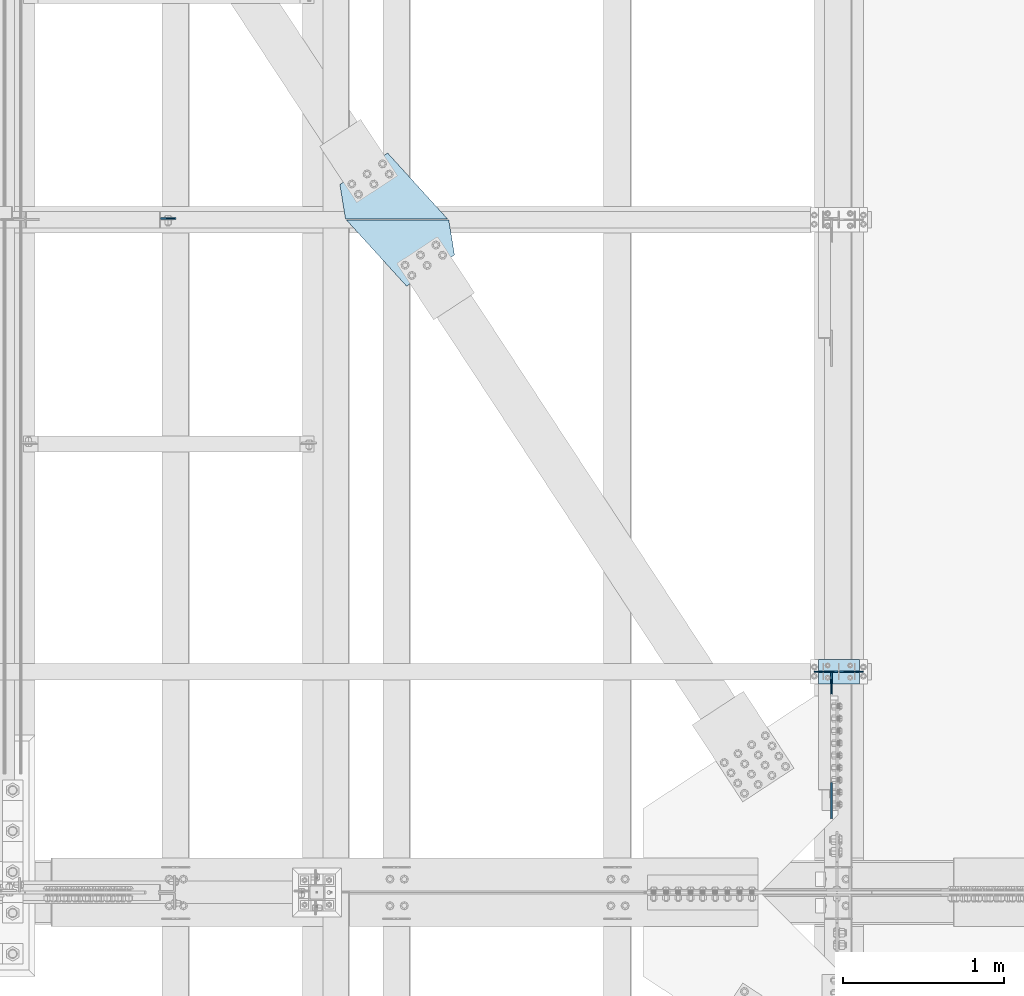
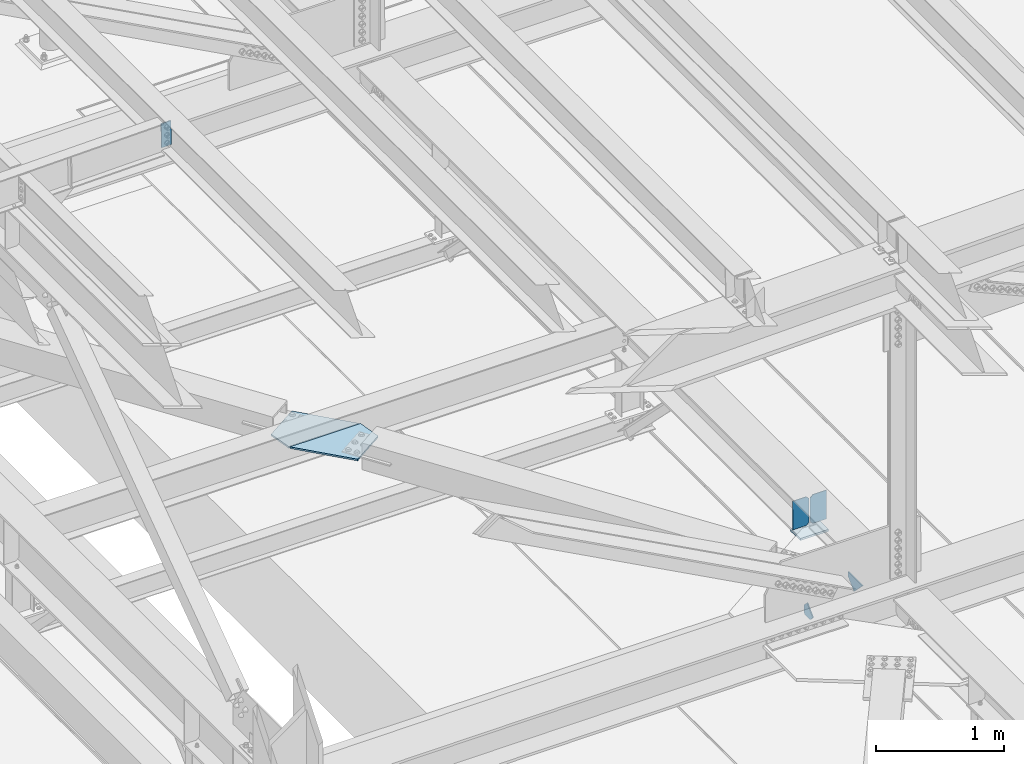
# One storey, part 3356 of 3843: 8 plates, 5 elements without a shape of their own.
"""IFC2X3 building model written with IfcOpenShell, lengths in millimetres."""

from ifc_helpers import new_model, si_unit, frame, origin_with_axes, place, context, subcontext, project, spatial, faceted_brep, material, type_object, element, aggregate, save


model = new_model("IFC2X3")

# Units and contexts
model_context = context("Model", 3, precision=1e-05, world=origin_with_axes())
body_context = subcontext(model_context, "Body", "Model", "MODEL_VIEW")
ifc_project = project(units=[si_unit("LENGTHUNIT", "METRE", prefix="MILLI"), si_unit("AREAUNIT", "SQUARE_METRE"), si_unit("VOLUMEUNIT", "CUBIC_METRE"), si_unit("MASSUNIT", "GRAM", prefix="KILO"), si_unit("TIMEUNIT", "SECOND"), si_unit("PLANEANGLEUNIT", "RADIAN"), si_unit("SOLIDANGLEUNIT", "STERADIAN"), si_unit("THERMODYNAMICTEMPERATUREUNIT", "DEGREE_CELSIUS"), si_unit("LUMINOUSINTENSITYUNIT", "LUMEN")], contexts=[model_context])

# Site, building, storey
site_placement = place(None, origin_with_axes())
site = spatial("IfcSite", under=ifc_project, at=site_placement, CompositionType="ELEMENT")
building_placement = place(site_placement, origin_with_axes())
building = spatial("IfcBuilding", under=site, at=building_placement, Name="Undefined", CompositionType="ELEMENT")
storey_placement = place(building_placement, origin_with_axes())
storey = spatial("IfcBuildingStorey", under=building, at=storey_placement, Name="Undefined", CompositionType="ELEMENT", Elevation=0.0)

# Assembly, plate
assembly_1_placement = place(storey_placement, origin_with_axes())
assembly_1 = element("IfcElementAssembly", 1, at=assembly_1_placement, inside=storey, Name="BEAM", AssemblyPlace="NOTDEFINED", PredefinedType="RIGID_FRAME")
ifc_material = material(Name="STEEL/A572-50")
plate_type_1 = type_object("IfcPlateType", PredefinedType="NOTDEFINED")
plate_1_placement = place(assembly_1_placement, frame((37938.8107286313, 71458.1407733637, 45720.3188601952), z_axis=(-0.999776269342228, -3.16699999781408e-06, -0.0211520980072162), x_axis=(0.0211520550054438, 0.0, -0.999776270257025)))
plate_1 = element("IfcPlate", 2, at=plate_1_placement, type_object=plate_type_1, material=ifc_material, Name="PLATE", context=body_context, shape_type="Brep", body=[
    faceted_brep([(0.0, -4.76249999999709, 0.0), (0.0, -4.76249999999709, 88.9000015258789), (0.0, 4.76249999999709, 88.9000015258789), (0.0, 4.76249999999709, 0.0), (228.600006102781, -4.7625000004191, 88.9000015257589), (228.600006102781, 4.76249999954598, 88.9000015257443), (228.600006103079, -4.7625000004482, 7.27595761418343e-12), (228.600006103079, 4.76249999954598, -7.27595761418343e-12)], [[[0, 1, 2, 3]], [[1, 4, 5, 2]], [[4, 6, 7, 5]], [[6, 0, 3, 7]], [[5, 7, 3, 2]], [[6, 4, 1, 0]]]),
])
aggregate(assembly_1, [plate_1])

# Assembly, plates
assembly_2_placement = place(storey_placement, origin_with_axes())
assembly_2 = element("IfcElementAssembly", 3, at=assembly_2_placement, inside=storey, Name="BEAM", AssemblyPlace="NOTDEFINED", PredefinedType="RIGID_FRAME")
plate_type_2 = type_object("IfcPlateType", PredefinedType="NOTDEFINED")
plate_2_placement = place(assembly_2_placement, frame((38998.3921820554, 71453.3750000002, 42238.6125), z_axis=(0.0, 1.0, 0.0), x_axis=(1.0, 0.0, 0.0)))
plate_2 = element("IfcPlate", 4, at=plate_2_placement, type_object=plate_type_2, material=ifc_material, context=body_context, shape_type="Brep", body=[
    faceted_brep([(0.0, -7.9375, 0.0), (-35.1641202014871, -7.9375, 215.056944640542), (-35.1641202014871, 7.9375, 215.056944640542), (0.0, 7.9375, 0.0), (262.095656278616, -7.9375, 410.218378553589), (262.095656278616, 7.9375, 410.218378553589), (635.186378621576, -7.9375, 0.0), (635.186378621576, 7.9375, 0.0)], [[[0, 1, 2, 3]], [[1, 4, 5, 2]], [[4, 6, 7, 5]], [[6, 0, 3, 7]], [[5, 7, 3, 2]], [[6, 4, 1, 0]]]),
])
plate_3_placement = place(assembly_2_placement, frame((39640.0078206491, 71447.0249999998, 42238.6125), z_axis=(0.0, -1.0, 0.0), x_axis=(-1.0, 0.0, 0.0)))
plate_3 = element("IfcPlate", 5, at=plate_3_placement, type_object=plate_type_2, material=ifc_material, context=body_context, shape_type="Brep", body=[
    faceted_brep([(0.0, -7.9375, 0.0), (-35.1641202014871, -7.9375, 215.056944640542), (-35.1641202014871, 7.9375, 215.056944640542), (0.0, 7.9375, 0.0), (262.095656278616, -7.9375, 410.218378553589), (262.095656278616, 7.9375, 410.218378553589), (635.186378621576, -7.9375, 0.0), (635.186378621576, 7.9375, 0.0)], [[[0, 1, 2, 3]], [[1, 4, 5, 2]], [[4, 6, 7, 5]], [[6, 0, 3, 7]], [[5, 7, 3, 2]], [[6, 4, 1, 0]]]),
])
aggregate(assembly_2, [plate_2, plate_3])

# Assembly, plate
assembly_3_placement = place(storey_placement, origin_with_axes())
assembly_3 = element("IfcElementAssembly", 6, at=assembly_3_placement, inside=storey, Name="POST", AssemblyPlace="NOTDEFINED", PredefinedType="RIGID_FRAME")
plate_type_3 = type_object("IfcPlateType", PredefinedType="NOTDEFINED")
plate_4_placement = place(assembly_3_placement, frame((41935.3999969059, 68719.6948793783, 42083.0375013706), z_axis=(0.0, -0.999999856112298, 0.00053644700005559), x_axis=(1.0, 0.0, 0.0)))
plate_4 = element("IfcPlate", 7, at=plate_4_placement, type_object=plate_type_3, material=ifc_material, Name="PLATE", context=body_context, shape_type="Brep", body=[
    faceted_brep([(0.0, -9.52500000000146, 0.0), (0.0, -9.5249999999287, 152.40000000162), (0.0, 9.52500000002328, 152.40000000162), (0.0, 9.52500000000146, 0.0), (254.0, -9.5249999999287, 152.40000000162), (254.0, 9.52500000002328, 152.40000000162), (253.999999999998, -9.52500000000146, 0.0), (253.999999999998, 9.52500000000146, 0.0)], [[[0, 1, 2, 3]], [[1, 4, 5, 2]], [[4, 6, 7, 5]], [[6, 0, 3, 7]], [[5, 7, 3, 2]], [[6, 4, 1, 0]]]),
])
aggregate(assembly_3, [plate_4])

assembly_4_placement = place(storey_placement, origin_with_axes())
assembly_4 = element("IfcElementAssembly", 8, at=assembly_4_placement, inside=storey, Name="BEAM", AssemblyPlace="NOTDEFINED", PredefinedType="RIGID_FRAME")
plate_type_4 = type_object("IfcPlateType", PredefinedType="NOTDEFINED")
plate_5_placement = place(assembly_4_placement, frame((42016.3625, 67731.1419690871, 42122.8620083264), z_axis=(0.0, 0.707106781186548, 0.707106781186548), x_axis=(5.70000238222118e-08, 0.707106781186546, -0.707106781186546)))
plate_5 = element("IfcPlate", 9, at=plate_5_placement, type_object=plate_type_4, material=ifc_material, Name="PLATE", context=body_context, shape_type="Brep", body=[
    faceted_brep([(0.0, -4.76249999999709, 0.0), (157.726597423803, -4.76249999999709, 157.726601438866), (157.726597423803, 4.76249999999709, 157.726601438866), (0.0, 4.76249999999709, 0.0), (188.387110059113, -4.76249999999709, 127.066089584019), (188.387110059113, 4.76249999999709, 127.066089584019), (188.387111679331, -4.76249999999709, 1.09139364212751e-10), (188.387111679331, 4.76249999999709, 1.09139364212751e-10)], [[[0, 1, 2, 3]], [[1, 4, 5, 2]], [[4, 6, 7, 5]], [[6, 0, 3, 7]], [[5, 7, 3, 2]], [[6, 4, 1, 0]]]),
])

assembly_5_placement = place(storey_placement, origin_with_axes())
assembly_5 = element("IfcElementAssembly", 10, at=assembly_5_placement, inside=storey, Name="BEAM", AssemblyPlace="NOTDEFINED", PredefinedType="RIGID_FRAME")
plate_type_5 = type_object("IfcPlateType", PredefinedType="NOTDEFINED")
plate_6_placement = place(assembly_5_placement, frame((42016.3625, 68640.3250000139, 41306.750000025), z_axis=(0.0, -1.0, 0.0), x_axis=(0.0, 0.0, 1.0)))
plate_6 = element("IfcPlate", 11, at=plate_6_placement, type_object=plate_type_5, material=ifc_material, Name="PLATE", context=body_context, shape_type="Brep", body=[
    faceted_brep([(0.0, -4.76250000000073, 12.6999998092651), (4.450703272596e-08, -4.76249999999709, 93.0710244828806), (4.450703272596e-08, 4.76249999999709, 93.0710244828806), (0.0, 4.76250000000073, 12.6999998092651), (43.3137807601452, -4.76249999999709, 136.384805065652), (43.3137807601452, 4.76249999999709, 136.384805065652), (133.209805202001, -4.76249999999709, 46.4887805392646), (133.209805202001, 4.76249999999709, 46.4887805392646), (86.7210245267561, -4.76249999999709, 0.0), (86.7210245267561, 4.76249999999709, 0.0), (12.6999998092651, -4.76250000000073, 0.0), (12.6999998092651, 4.76250000000073, 0.0)], [[[0, 1, 2, 3]], [[1, 4, 5, 2]], [[4, 6, 7, 5]], [[6, 8, 9, 7]], [[8, 10, 11, 9]], [[10, 0, 3, 11]], [[5, 7, 9, 11, 3, 2]], [[10, 8, 6, 4, 1, 0]]]),
])
aggregate(assembly_5, [plate_6])

# Plate
plate_type_6 = type_object("IfcPlateType", PredefinedType="NOTDEFINED")
plate_7_placement = place(assembly_4_placement, frame((42214.8, 68643.6558445591, 42412.9332591827), z_axis=(0.0, -0.00053644700004952, -0.999999856112298), x_axis=(-1.0, 0.0, 0.0)))
plate_7 = element("IfcPlate", 12, at=plate_7_placement, type_object=plate_type_6, material=ifc_material, Name="PLATE", context=body_context, shape_type="Brep", body=[
    faceted_brep([(0.0, -3.17499999999927, 0.0), (0.0, -3.17500000007567, 273.049999997937), (0.0, 3.17499999993743, 273.049999997937), (0.0, 3.17499999999927, 0.0), (122.237500389827, -3.17500000007567, 273.049999997937), (122.237500389827, 3.17499999993743, 273.049999997937), (147.637500008357, -3.17500000006476, 247.650000379464), (147.637500008357, 3.17499999994106, 247.650000379464), (147.637500008357, -3.17500000001382, 25.3999996184648), (147.637500008357, 3.17499999999927, 25.3999996184648), (122.237500389827, -3.17500000000291, 0.0), (122.237500389827, 3.17500000000291, -7.27595761418343e-12)], [[[0, 1, 2, 3]], [[1, 4, 5, 2]], [[4, 6, 7, 5]], [[6, 8, 9, 7]], [[8, 10, 11, 9]], [[10, 0, 3, 11]], [[5, 7, 9, 11, 3, 2]], [[10, 8, 6, 4, 1, 0]]]),
])

plate_8_placement = place(assembly_4_placement, frame((41910.0, 68643.6558445591, 42412.9332591827), z_axis=(0.0, -0.00053644700004952, -0.999999856112298), x_axis=(1.0, 0.0, 0.0)))
plate_8 = element("IfcPlate", 13, at=plate_8_placement, type_object=plate_type_6, material=ifc_material, Name="PLATE", context=body_context, shape_type="Brep", body=[
    faceted_brep([(0.0, -3.17499999999927, 0.0), (0.0, -3.17500000007567, 273.049999997937), (0.0, 3.17499999993743, 273.049999997937), (0.0, 3.17499999999927, 0.0), (122.237500389827, -3.17500000007567, 273.049999997937), (122.237500389827, 3.17499999993743, 273.049999997937), (147.637500008357, -3.17500000006476, 247.650000379464), (147.637500008357, 3.17499999994106, 247.650000379464), (147.637500008357, -3.17500000001382, 25.3999996184648), (147.637500008357, 3.17499999999927, 25.3999996184648), (122.237500389827, -3.17500000000291, 0.0), (122.237500389827, 3.17500000000291, -7.27595761418343e-12)], [[[0, 1, 2, 3]], [[1, 4, 5, 2]], [[4, 6, 7, 5]], [[6, 8, 9, 7]], [[8, 10, 11, 9]], [[10, 0, 3, 11]], [[5, 7, 9, 11, 3, 2]], [[10, 8, 6, 4, 1, 0]]]),
])

aggregate(assembly_4, [plate_5, plate_7, plate_8])

save(model, "model.ifc")
